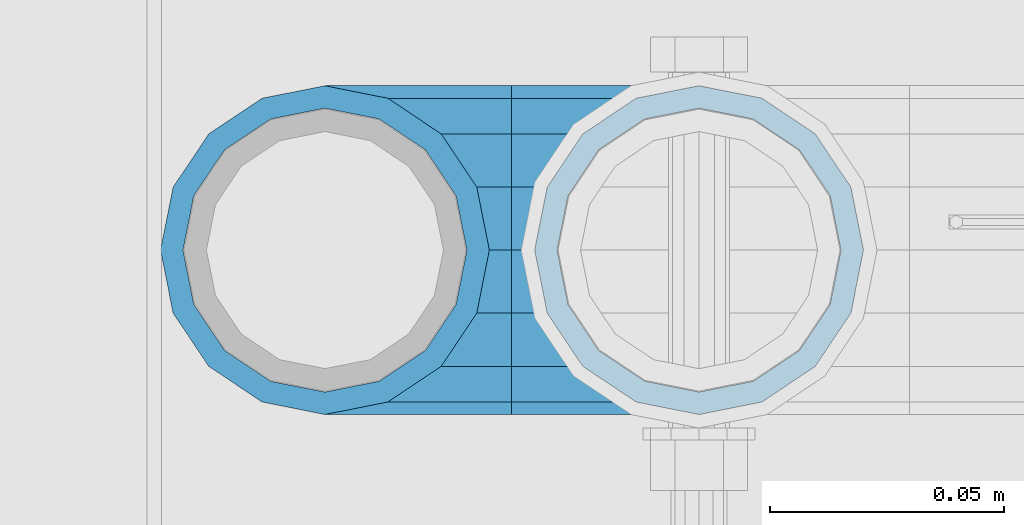
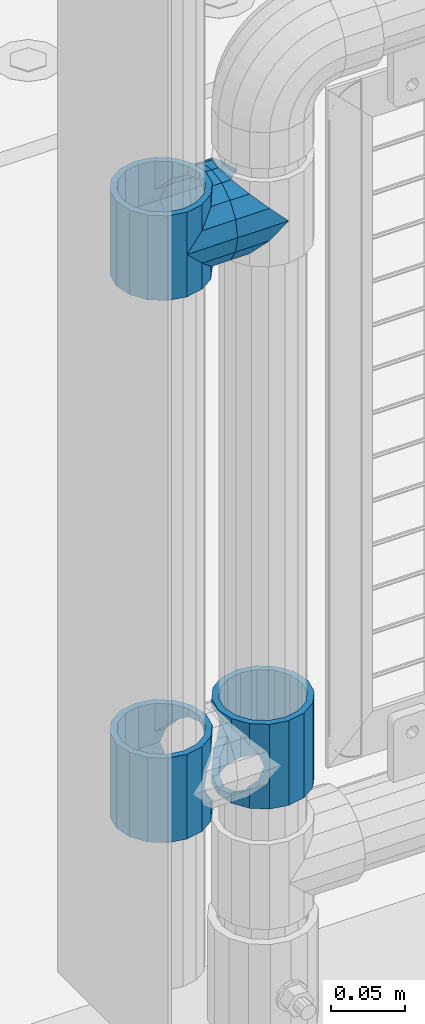
# One storey, part 145 of 240: 5 beams.
"""IFC2X3 building model written with IfcOpenShell, lengths in millimetres."""

from ifc_helpers import new_model, si_unit, frame, origin_with_axes, place, context, subcontext, project, spatial, faceted_brep, material, type_object, element, save


model = new_model("IFC2X3")

# Units and contexts
model_context = context("Model", 3, precision=1e-05, world=origin_with_axes())
body_context = subcontext(model_context, "Body", "Model", "MODEL_VIEW")
ifc_project = project(units=[si_unit("LENGTHUNIT", "METRE", prefix="MILLI"), si_unit("AREAUNIT", "SQUARE_METRE"), si_unit("VOLUMEUNIT", "CUBIC_METRE"), si_unit("MASSUNIT", "GRAM", prefix="KILO"), si_unit("TIMEUNIT", "SECOND"), si_unit("PLANEANGLEUNIT", "RADIAN"), si_unit("SOLIDANGLEUNIT", "STERADIAN"), si_unit("THERMODYNAMICTEMPERATUREUNIT", "DEGREE_CELSIUS"), si_unit("LUMINOUSINTENSITYUNIT", "LUMEN")], contexts=[model_context])

# Site, building, storey
site_placement = place(None, origin_with_axes())
site = spatial("IfcSite", under=ifc_project, at=site_placement, CompositionType="ELEMENT")
building_placement = place(site_placement, origin_with_axes())
building = spatial("IfcBuilding", under=site, at=building_placement, Name="Standard", CompositionType="ELEMENT")
storey_placement = place(building_placement, origin_with_axes())
storey = spatial("IfcBuildingStorey", under=building, at=storey_placement, Name="Undefined", CompositionType="ELEMENT", Elevation=0.0)

# Beams
ifc_material = material(Name="Misc_Undefined")
beam_type = type_object("IfcBeamType", PredefinedType="NOTDEFINED")
beam_1_placement = place(storey_placement, frame((42991.0, 34664.5, 433.820000000001), z_axis=(-1.0, 0.0, 0.0), x_axis=(0.0, 0.0, -1.0)))
element("IfcBeam", 1, at=beam_1_placement, inside=storey, type_object=beam_type, material=ifc_material, context=body_context, shape_type="Brep", body=[
    faceted_brep([(13.6893091909879, -21.4606908090136, -21.4606908090136), (13.6893091909879, -21.4606908090136, -27.1226768591223), (8.33762048232455, -13.4513226476338, -32.4743655677739), (7.11025618828211, -11.6144421722784, -32.8397438117245), (7.11025618828211, -11.6144421722784, -28.0397438117143), (23.5355578277191, -28.0397438117143, -11.6144421722784), (23.5355578277191, -28.0397438117143, -20.0882031229994), (18.7689575919987, -24.8548033587067, -24.8548033587067), (35.1500000000015, -30.35, 0.0), (35.1499999999996, -30.3499999999985, -16.6306603983758), (46.7644421722801, -28.0397438117143, -11.6144421722784), (46.7644421722801, -28.0397438117143, -20.0882031229994), (56.6106908090114, -21.4606908090136, -21.4606908090136), (56.6106908090114, -21.4606908090136, -27.1226768591223), (51.5310424080006, -24.8548033587067, -24.8548033587067), (63.1897438117172, -11.6144421722784, -28.0397438117143), (63.1897438117172, -11.6144421722784, -32.8397438117245), (61.9623795176703, -13.4513226476338, -32.4743655677739), (65.4999999999997, 0.0, -30.3499999999985), (65.4999999999997, 0.0, -35.1500000000015), (63.1897438117172, 11.6144421722784, -28.0397438117143), (63.1897438117172, 11.6144421722784, -32.8397438117172), (56.6106908090114, 21.4606908090136, -21.4606908090136), (56.6106908090114, 21.4606908090136, -27.1226768591077), (61.9623795176703, 13.4513226476338, -32.4743655677739), (46.7644421722801, 28.0397438117143, -11.6144421722784), (46.7644421722801, 28.0397438117143, -20.0882031229849), (51.5310424079941, 24.8548033587067, -24.8548033587067), (35.1500000000015, 30.35, 0.0), (35.1499999999996, 30.3499999999985, -16.6306603983685), (23.5355578277192, 28.0397438117143, -11.6144421722784), (23.5355578277192, 28.0397438117143, -20.0882031229849), (13.6893091909879, 21.4606908090136, -21.4606908090136), (13.6893091909879, 21.4606908090136, -27.1226768591077), (18.7689575919921, 24.8548033587067, -24.8548033587067), (7.11025618828211, 11.6144421722784, -28.0397438117143), (7.11025618828211, 11.6144421722784, -32.8397438117172), (8.33762048232893, 13.4513226476338, -32.4743655677739), (4.79999999999961, 0.0, -30.3499999999985), (4.79999999999961, 0.0, -35.1500000000015), (0.0, 21.4606908090136, 21.4606908090136), (0.0, 28.0397438117143, 11.6144421722784), (70.2999999999993, 28.0397438117143, 11.6144421722784), (70.2999999999993, 21.4606908090136, 21.4606908090136), (0.0, 11.6144421722784, 28.0397438117143), (70.2999999999993, 11.6144421722784, 28.0397438117143), (0.0, 0.0, 30.3499999999985), (70.2999999999993, 0.0, 30.3499999999985), (0.0, -11.6144421722784, 28.0397438117143), (70.2999999999993, -11.6144421722784, 28.0397438117143), (0.0, -21.4606908090136, 21.4606908090136), (70.2999999999993, -21.4606908090136, 21.4606908090136), (0.0, -28.0397438117143, 11.6144421722784), (70.2999999999993, -28.0397438117143, 11.6144421722784), (0.0, -24.8548033587067, -24.8548033587067), (0.0, -13.4513226476338, -32.4743655677739), (0.0, 0.0, -35.1500000000015), (0.0, -32.4743655677739, 13.4513226476338), (0.0, -35.1500000000015, 0.0), (70.2999999999993, -35.1500000000015, 0.0), (70.2999999999993, -32.4743655677739, 13.4513226476338), (0.0, -24.8548033587067, 24.8548033587067), (70.2999999999993, -24.8548033587067, 24.8548033587067), (0.0, -13.4513226476338, 32.4743655677739), (70.2999999999993, -13.4513226476338, 32.4743655677739), (0.0, 0.0, 35.1500000000015), (70.2999999999993, 0.0, 35.1500000000015), (0.0, 13.4513226476338, 32.4743655677739), (70.2999999999993, 13.4513226476338, 32.4743655677739), (0.0, 24.8548033587067, 24.8548033587067), (70.2999999999993, 24.8548033587067, 24.8548033587067), (0.0, 32.4743655677739, 13.4513226476338), (70.2999999999993, 32.4743655677739, 13.4513226476338), (0.0, 35.1500000000015, 0.0), (70.2999999999993, 35.1500000000015, 0.0), (0.0, 32.4743655677739, -13.4513226476338), (70.2999999999993, 32.4743655677739, -13.4513226476338), (70.2999999999993, -13.4513226476338, -32.4743655677739), (70.2999999999993, -24.8548033587067, -24.8548033587067), (70.2999999999993, 0.0, -35.1500000000015), (70.2999999999993, 13.4513226476338, -32.4743655677739), (70.2999999999993, 24.8548033587067, -24.8548033587067), (0.0, 24.8548033587067, -24.8548033587067), (0.0, 13.4513226476338, -32.4743655677739), (70.2999999999993, -32.4743655677739, -13.4513226476338), (0.0, -32.4743655677739, -13.4513226476338), (0.0, -28.0397438117143, -11.6144421722784), (0.0, -21.4606908090136, -21.4606908090136), (0.0, -11.6144421722784, -28.0397438117143), (0.0, 0.0, -30.3499999999985), (0.0, 11.6144421722784, -28.0397438117143), (0.0, 21.4606908090136, -21.4606908090136), (0.0, 28.0397438117143, -11.6144421722784), (0.0, 30.3499999999985, 0.0), (0.0, -30.3499999999985, 0.0), (70.2999999999993, 30.3499999999985, 0.0), (70.2999999999993, 28.0397438117143, -11.6144421722784), (70.2999999999993, 21.4606908090136, -21.4606908090136), (70.2999999999993, 11.6144421722784, -28.0397438117143), (70.2999999999993, 0.0, -30.3499999999985), (70.2999999999993, -11.6144421722784, -28.0397438117143), (70.2999999999993, -21.4606908090136, -21.4606908090136), (70.2999999999993, -28.0397438117143, -11.6144421722784), (70.2999999999993, -30.3499999999985, 0.0)], [[[0, 1, 2, 3, 4]], [[5, 6, 7, 1, 0]], [[8, 9, 6, 5]], [[10, 11, 9, 8]], [[12, 13, 14, 11, 10]], [[15, 16, 17, 13, 12]], [[18, 19, 16, 15]], [[20, 21, 19, 18]], [[22, 23, 24, 21, 20]], [[25, 26, 27, 23, 22]], [[28, 29, 26, 25]], [[30, 31, 29, 28]], [[32, 33, 34, 31, 30]], [[35, 36, 37, 33, 32]], [[38, 39, 36, 35]], [[4, 3, 39, 38]], [[40, 41, 42, 43]], [[44, 40, 43, 45]], [[46, 44, 45, 47]], [[48, 46, 47, 49]], [[50, 48, 49, 51]], [[52, 50, 51, 53]], [[54, 55, 2, 1, 7]], [[55, 56, 39, 3, 2]], [[57, 58, 59, 60]], [[61, 57, 60, 62]], [[63, 61, 62, 64]], [[65, 63, 64, 66]], [[67, 65, 66, 68]], [[69, 67, 68, 70]], [[71, 69, 70, 72]], [[73, 71, 72, 74]], [[75, 73, 74, 76]], [[17, 77, 78, 14, 13]], [[19, 79, 77, 17, 16]], [[80, 79, 19, 21, 24]], [[81, 80, 24, 23, 27]], [[34, 82, 75, 76, 81, 27, 26, 29, 31]], [[37, 83, 82, 34, 33]], [[39, 56, 83, 37, 36]], [[14, 78, 84, 85, 54, 7, 6, 9, 11]], [[58, 85, 84, 59]], [[57, 61, 63, 65, 67, 69, 71, 73, 75, 82, 83, 56, 55, 54, 85, 58], [86, 87, 88, 89, 90, 91, 92, 93, 41, 40, 44, 46, 48, 50, 52, 94]], [[90, 89, 38, 35]], [[91, 90, 35, 32]], [[92, 91, 32, 30]], [[93, 92, 30, 28]], [[41, 93, 28, 95, 42]], [[96, 95, 28, 25]], [[97, 96, 25, 22]], [[98, 97, 22, 20]], [[99, 98, 20, 18]], [[100, 99, 18, 15]], [[101, 100, 15, 12]], [[102, 101, 12, 10]], [[103, 102, 10, 8]], [[78, 77, 79, 80, 81, 76, 74, 72, 70, 68, 66, 64, 62, 60, 59, 84], [51, 49, 47, 45, 43, 42, 95, 96, 97, 98, 99, 100, 101, 102, 103, 53]], [[8, 94, 52, 53, 103]], [[86, 94, 8, 5]], [[87, 86, 5, 0]], [[88, 87, 0, 4]], [[89, 88, 4, 38]]]),
])
beam_2_placement = place(storey_placement, frame((43071.0, 34664.5, 433.820000000001), z_axis=(1.0, 0.0, 0.0), x_axis=(0.0, 0.0, -1.0)))
element("IfcBeam", 2, at=beam_2_placement, inside=storey, type_object=beam_type, material=ifc_material, context=body_context, shape_type="Brep", body=[
    faceted_brep([(46.7644421722801, 28.0397438117143, -11.6144421722784), (46.7644421722801, 28.0397438117143, -20.0882031229849), (51.5310424079941, 24.8548033587067, -24.8548033587067), (56.6106908090114, 21.4606908090136, -27.1226768591077), (56.6106908090114, 21.4606908090136, -21.4606908090136), (61.9623795176703, 13.4513226476338, -32.4743655677739), (63.1897438117172, 11.6144421722784, -32.8397438117172), (63.1897438117172, 11.6144421722784, -28.0397438117143), (65.4999999999997, 0.0, -35.1500000000015), (65.4999999999997, 0.0, -30.3499999999985), (63.1897438117172, -11.6144421722784, -32.8397438117245), (63.1897438117172, -11.6144421722784, -28.0397438117143), (61.9623795176703, -13.4513226476338, -32.4743655677739), (56.6106908090114, -21.4606908090136, -27.1226768591223), (56.6106908090114, -21.4606908090136, -21.4606908090136), (51.5310424080006, -24.8548033587067, -24.8548033587067), (46.7644421722801, -28.0397438117143, -20.0882031229994), (46.7644421722801, -28.0397438117143, -11.6144421722784), (35.1499999999996, -30.3499999999985, -16.6306603983758), (35.1500000000015, -30.35, 0.0), (23.5355578277191, -28.0397438117143, -20.0882031229994), (23.5355578277191, -28.0397438117143, -11.6144421722784), (18.7689575919987, -24.8548033587067, -24.8548033587067), (13.6893091909879, -21.4606908090136, -27.1226768591223), (13.6893091909879, -21.4606908090136, -21.4606908090136), (8.33762048232455, -13.4513226476338, -32.4743655677739), (7.11025618828211, -11.6144421722784, -32.8397438117245), (7.11025618828211, -11.6144421722784, -28.0397438117143), (4.79999999999961, 0.0, -35.1500000000015), (4.79999999999961, 0.0, -30.3499999999985), (7.11025618828211, 11.6144421722784, -32.8397438117172), (7.11025618828211, 11.6144421722784, -28.0397438117143), (8.33762048232893, 13.4513226476338, -32.4743655677739), (13.6893091909879, 21.4606908090136, -27.1226768591077), (13.6893091909879, 21.4606908090136, -21.4606908090136), (18.7689575919921, 24.8548033587067, -24.8548033587067), (23.5355578277192, 28.0397438117143, -20.0882031229849), (23.5355578277192, 28.0397438117143, -11.6144421722784), (35.1499999999996, 30.3499999999985, -16.6306603983685), (35.1500000000015, 30.35, 0.0), (0.0, 32.4743655677739, -13.4513226476338), (0.0, 35.1500000000015, 0.0), (70.2999999999993, 35.1500000000015, 0.0), (70.2999999999993, 32.4743655677739, -13.4513226476338), (0.0, 32.4743655677739, 13.4513226476338), (70.2999999999993, 32.4743655677739, 13.4513226476338), (0.0, 24.8548033587067, 24.8548033587067), (70.2999999999993, 24.8548033587067, 24.8548033587067), (0.0, 13.4513226476338, 32.4743655677739), (70.2999999999993, 13.4513226476338, 32.4743655677739), (0.0, 0.0, 35.1500000000015), (70.2999999999993, 0.0, 35.1500000000015), (0.0, -13.4513226476338, 32.4743655677739), (70.2999999999993, -13.4513226476338, 32.4743655677739), (0.0, -24.8548033587067, 24.8548033587067), (70.2999999999993, -24.8548033587067, 24.8548033587067), (0.0, -32.4743655677739, 13.4513226476338), (70.2999999999993, -32.4743655677739, 13.4513226476338), (0.0, -35.1500000000015, 0.0), (70.2999999999993, -35.1500000000015, 0.0), (70.2999999999993, -30.3499999999985, 0.0), (70.2999999999993, -28.0397438117143, -11.6144421722784), (70.2999999999993, -21.4606908090136, -21.4606908090136), (70.2999999999993, -11.6144421722784, -28.0397438117143), (70.2999999999993, 0.0, -30.3499999999985), (70.2999999999993, 11.6144421722784, -28.0397438117143), (70.2999999999993, 21.4606908090136, -21.4606908090136), (70.2999999999993, 28.0397438117143, -11.6144421722784), (0.0, -28.0397438117143, -11.6144421722784), (0.0, -30.3499999999985, 0.0), (0.0, -21.4606908090136, -21.4606908090136), (0.0, -11.6144421722784, -28.0397438117143), (0.0, 0.0, -30.3499999999985), (0.0, 11.6144421722784, -28.0397438117143), (0.0, 21.4606908090136, -21.4606908090136), (0.0, 28.0397438117143, -11.6144421722784), (0.0, 30.3499999999985, 0.0), (70.2999999999993, 30.3499999999985, 0.0), (0.0, 28.0397438117143, 11.6144421722784), (70.2999999999993, 28.0397438117143, 11.6144421722784), (0.0, 21.4606908090136, 21.4606908090136), (70.2999999999993, 21.4606908090136, 21.4606908090136), (0.0, 11.6144421722784, 28.0397438117143), (70.2999999999993, 11.6144421722784, 28.0397438117143), (0.0, 0.0, 30.3499999999985), (70.2999999999993, 0.0, 30.3499999999985), (0.0, -11.6144421722784, 28.0397438117143), (70.2999999999993, -11.6144421722784, 28.0397438117143), (0.0, -21.4606908090136, 21.4606908090136), (70.2999999999993, -21.4606908090136, 21.4606908090136), (0.0, -28.0397438117143, 11.6144421722784), (70.2999999999993, -28.0397438117143, 11.6144421722784), (70.2999999999993, -24.8548033587067, -24.8548033587067), (70.2999999999993, -13.4513226476338, -32.4743655677739), (70.2999999999993, 0.0, -35.1500000000015), (70.2999999999993, 13.4513226476338, -32.4743655677739), (70.2999999999993, 24.8548033587067, -24.8548033587067), (70.2999999999993, -32.4743655677739, -13.4513226476338), (0.0, -32.4743655677739, -13.4513226476338), (0.0, 24.8548033587067, -24.8548033587067), (0.0, 13.4513226476338, -32.4743655677739), (0.0, 0.0, -35.1500000000015), (0.0, -13.4513226476338, -32.4743655677739), (0.0, -24.8548033587067, -24.8548033587067)], [[[0, 1, 2, 3, 4]], [[4, 3, 5, 6, 7]], [[7, 6, 8, 9]], [[9, 8, 10, 11]], [[11, 10, 12, 13, 14]], [[14, 13, 15, 16, 17]], [[17, 16, 18, 19]], [[19, 18, 20, 21]], [[21, 20, 22, 23, 24]], [[24, 23, 25, 26, 27]], [[27, 26, 28, 29]], [[29, 28, 30, 31]], [[31, 30, 32, 33, 34]], [[34, 33, 35, 36, 37]], [[37, 36, 38, 39]], [[39, 38, 1, 0]], [[40, 41, 42, 43]], [[41, 44, 45, 42]], [[44, 46, 47, 45]], [[46, 48, 49, 47]], [[48, 50, 51, 49]], [[50, 52, 53, 51]], [[52, 54, 55, 53]], [[54, 56, 57, 55]], [[56, 58, 59, 57]], [[60, 61, 17, 19]], [[61, 62, 14, 17]], [[62, 63, 11, 14]], [[63, 64, 9, 11]], [[64, 65, 7, 9]], [[65, 66, 4, 7]], [[66, 67, 0, 4]], [[68, 69, 19, 21]], [[70, 68, 21, 24]], [[71, 70, 24, 27]], [[72, 71, 27, 29]], [[73, 72, 29, 31]], [[74, 73, 31, 34]], [[75, 74, 34, 37]], [[76, 75, 37, 39]], [[67, 77, 39, 0]], [[78, 76, 39, 77, 79]], [[80, 78, 79, 81]], [[82, 80, 81, 83]], [[84, 82, 83, 85]], [[86, 84, 85, 87]], [[88, 86, 87, 89]], [[90, 88, 89, 91]], [[19, 69, 90, 91, 60]], [[92, 93, 94, 95, 96, 43, 42, 45, 47, 49, 51, 53, 55, 57, 59, 97], [89, 87, 85, 83, 81, 79, 77, 67, 66, 65, 64, 63, 62, 61, 60, 91]], [[58, 98, 97, 59]], [[56, 54, 52, 50, 48, 46, 44, 41, 40, 99, 100, 101, 102, 103, 98, 58], [68, 70, 71, 72, 73, 74, 75, 76, 78, 80, 82, 84, 86, 88, 90, 69]], [[32, 100, 99, 35, 33]], [[28, 101, 100, 32, 30]], [[102, 101, 28, 26, 25]], [[103, 102, 25, 23, 22]], [[15, 92, 97, 98, 103, 22, 20, 18, 16]], [[12, 93, 92, 15, 13]], [[8, 94, 93, 12, 10]], [[95, 94, 8, 6, 5]], [[96, 95, 5, 3, 2]], [[35, 99, 40, 43, 96, 2, 1, 38, 36]]]),
])
beam_3_placement = place(storey_placement, frame((42991.0, 34664.5, 848.670000000001), z_axis=(0.0, -1.0, 0.0), x_axis=(1.0, 0.0, 0.0)))
element("IfcBeam", 3, at=beam_3_placement, inside=storey, type_object=beam_type, material=ifc_material, context=body_context, shape_type="Brep", body=[
    faceted_brep([(0.0, 0.0, -35.1500000000015), (13.4513226476338, -13.4513226476329, -32.4743655677739), (13.4513226476338, 13.4513226476329, -32.4743655677739), (32.4743655677739, 32.4743655677717, 13.4513226476338), (32.4743655677739, 26.8123795176755, 13.4513226476338), (27.1226768591005, 21.4606908090117, 21.4606908090136), (24.8548033587067, 16.3810424080013, 24.8548033587067), (24.8548033587067, 24.8548033587072, 24.8548033587067), (0.0, 0.0, 35.1500000000015), (13.4513226476338, 13.4513226476329, 32.4743655677739), (13.4513226476338, -13.4513226476329, 32.4743655677739), (20.0882031229849, 11.6144421722805, 28.0397438117143), (16.6306603983685, 0.0, 30.3499999999985), (20.0882031229849, -11.6144421722805, 28.0397438117143), (24.8548033587067, -16.3810424080078, 24.8548033587067), (24.8548033587067, -24.8548033587072, 24.8548033587067), (27.1226768591005, -21.4606908090117, 21.4606908090136), (32.4743655677739, -26.8123795176712, 13.4513226476338), (32.4743655677739, -32.4743655677717, 13.4513226476338), (32.8397438117099, -28.0397438117175, 11.6144421722784), (35.1500000000015, -30.35, 0.0), (35.1500000000015, -35.15, 0.0), (32.4743655677739, -26.8123795176712, -13.4513226476338), (32.4743655677739, -32.4743655677717, -13.4513226476338), (32.8397438117172, -28.0397438117175, -11.6144421722784), (24.8548033587067, -16.3810424079947, -24.8548033587067), (24.8548033587067, -24.8548033587072, -24.8548033587067), (27.1226768591223, -21.4606908090117, -21.4606908090136), (20.0882031229994, -11.6144421722805, -28.0397438117143), (16.6306603983758, 0.0, -30.3499999999985), (20.0882031229994, 11.6144421722805, -28.0397438117143), (24.8548033587067, 16.3810424080013, -24.8548033587067), (24.8548033587067, 24.8548033587072, -24.8548033587067), (27.1226768591223, 21.4606908090117, -21.4606908090136), (32.4743655677739, 26.8123795176712, -13.4513226476338), (32.4743655677739, 32.4743655677717, -13.4513226476338), (32.8397438117172, 28.0397438117175, -11.6144421722784), (35.1500000000015, 30.35, 0.0), (35.1500000000015, 35.15, 0.0), (32.8397438117099, 28.0397438117175, 11.6144421722784), (40.1500000000015, -35.15, 0.0), (40.1500000000015, -32.4743655677717, 13.4513226476338), (40.1500000000015, -24.8548033587072, 24.8548033587067), (40.1500000000015, -13.4513226476329, 32.4743655677739), (40.1500000000015, 0.0, 35.1500000000015), (40.1500000000015, 13.4513226476329, 32.4743655677739), (40.1500000000015, 24.8548033587072, 24.8548033587067), (40.1500000000015, 32.4743655677717, 13.4513226476338), (40.1500000000015, 35.15, 0.0), (40.1500000000015, -24.8548033587072, -24.8548033587067), (40.1500000000015, -32.4743655677717, -13.4513226476338), (40.1500000000015, -13.4513226476329, -32.4743655677739), (40.1500000000015, 0.0, -35.1500000000015), (40.1500000000015, 13.4513226476329, -32.4743655677739), (40.1500000000015, 24.8548033587072, -24.8548033587067), (40.1500000000015, 32.4743655677717, -13.4513226476338), (40.1500000000015, -21.4606908090117, 21.4606908090136), (40.1500000000015, -11.6144421722805, 28.0397438117143), (40.1500000000015, 0.0, 30.3499999999985), (40.1500000000015, 11.6144421722805, 28.0397438117143), (40.1500000000015, 21.4606908090117, 21.4606908090136), (40.1500000000015, 28.0397438117175, 11.6144421722784), (40.1500000000015, 30.35, 0.0), (40.1500000000015, 28.0397438117175, -11.6144421722784), (40.1500000000015, 21.4606908090117, -21.4606908090136), (40.1500000000015, 11.6144421722805, -28.0397438117143), (40.1500000000015, 0.0, -30.3499999999985), (40.1500000000015, -11.6144421722805, -28.0397438117143), (40.1500000000015, -21.4606908090117, -21.4606908090136), (40.1500000000015, -28.0397438117175, -11.6144421722784), (40.1500000000015, -30.35, 0.0), (40.1500000000015, -28.0397438117175, 11.6144421722784)], [[[0, 1, 2]], [[3, 4, 5, 6, 7]], [[8, 9, 10]], [[7, 6, 11, 12, 13, 14, 15, 10, 9]], [[16, 17, 18, 15, 14]], [[19, 20, 21, 18, 17]], [[22, 23, 21, 20, 24]], [[25, 26, 23, 22, 27]], [[2, 1, 26, 25, 28, 29, 30, 31, 32]], [[32, 31, 33, 34, 35]], [[35, 34, 36, 37, 38]], [[38, 37, 39, 4, 3]], [[40, 41, 18, 21]], [[41, 42, 15, 18]], [[42, 43, 10, 15]], [[43, 44, 8, 10]], [[44, 45, 9, 8]], [[45, 46, 7, 9]], [[46, 47, 3, 7]], [[47, 48, 38, 3]], [[49, 50, 23, 26]], [[51, 49, 26, 1]], [[52, 51, 1, 0]], [[53, 52, 0, 2]], [[54, 53, 2, 32]], [[55, 54, 32, 35]], [[48, 55, 35, 38]], [[50, 40, 21, 23]], [[49, 51, 52, 53, 54, 55, 48, 47, 46, 45, 44, 43, 42, 41, 40, 50], [56, 57, 58, 59, 60, 61, 62, 63, 64, 65, 66, 67, 68, 69, 70, 71]], [[63, 62, 37, 36]], [[33, 64, 63, 36, 34]], [[30, 65, 64, 33, 31]], [[66, 65, 30, 29]], [[67, 66, 29, 28]], [[68, 67, 28, 25, 27]], [[69, 68, 27, 22, 24]], [[70, 69, 24, 20]], [[71, 70, 20, 19]], [[16, 56, 71, 19, 17]], [[13, 57, 56, 16, 14]], [[58, 57, 13, 12]], [[59, 58, 12, 11]], [[60, 59, 11, 6, 5]], [[61, 60, 5, 4, 39]], [[62, 61, 39, 37]]]),
])
beam_4_placement = place(storey_placement, frame((43071.0, 34664.5, 848.670000000001), z_axis=(0.0, 1.0, 0.0), x_axis=(-1.0, 0.0, 0.0)))
element("IfcBeam", 4, at=beam_4_placement, inside=storey, type_object=beam_type, material=ifc_material, context=body_context, shape_type="Brep", body=[
    faceted_brep([(0.0, 0.0, -35.1500000000015), (13.4513226476338, -13.4513226476329, -32.4743655677739), (13.4513226476338, 13.4513226476329, -32.4743655677739), (27.1226768591005, -21.4606908090117, 21.4606908090136), (32.4743655677739, -26.8123795176712, 13.4513226476338), (32.4743655677739, -32.4743655677717, 13.4513226476338), (24.8548033587067, -24.8548033587072, 24.8548033587067), (24.8548033587067, -16.3810424080078, 24.8548033587067), (32.8397438117099, -28.0397438117175, 11.6144421722784), (35.1500000000015, -30.35, 0.0), (35.1500000000015, -35.15, 0.0), (32.4743655677739, -26.8123795176712, -13.4513226476338), (32.4743655677739, -32.4743655677717, -13.4513226476338), (32.8397438117172, -28.0397438117175, -11.6144421722784), (24.8548033587067, -16.3810424079947, -24.8548033587067), (24.8548033587067, -24.8548033587072, -24.8548033587067), (27.1226768591223, -21.4606908090117, -21.4606908090136), (20.0882031229994, -11.6144421722805, -28.0397438117143), (16.6306603983758, 0.0, -30.3499999999985), (20.0882031229994, 11.6144421722805, -28.0397438117143), (24.8548033587067, 16.3810424080013, -24.8548033587067), (24.8548033587067, 24.8548033587072, -24.8548033587067), (27.1226768591223, 21.4606908090117, -21.4606908090136), (32.4743655677739, 26.8123795176712, -13.4513226476338), (32.4743655677739, 32.4743655677717, -13.4513226476338), (32.8397438117172, 28.0397438117175, -11.6144421722784), (35.1500000000015, 30.35, 0.0), (35.1500000000015, 35.15, 0.0), (32.8397438117099, 28.0397438117175, 11.6144421722784), (32.4743655677739, 26.8123795176755, 13.4513226476338), (32.4743655677739, 32.4743655677717, 13.4513226476338), (27.1226768591005, 21.4606908090117, 21.4606908090136), (24.8548033587067, 16.3810424080013, 24.8548033587067), (24.8548033587067, 24.8548033587072, 24.8548033587067), (0.0, 0.0, 35.1500000000015), (13.4513226476338, 13.4513226476329, 32.4743655677739), (13.4513226476338, -13.4513226476329, 32.4743655677739), (20.0882031229849, 11.6144421722805, 28.0397438117143), (16.6306603983685, 0.0, 30.3499999999985), (20.0882031229849, -11.6144421722805, 28.0397438117143), (40.1500000000015, -35.15, 0.0), (40.1500000000015, -32.4743655677717, 13.4513226476338), (40.1500000000015, -24.8548033587072, 24.8548033587067), (40.1500000000015, -13.4513226476329, 32.4743655677739), (40.1500000000015, 0.0, 35.1500000000015), (40.1500000000015, -24.8548033587072, -24.8548033587067), (40.1500000000015, -32.4743655677717, -13.4513226476338), (40.1500000000015, -13.4513226476329, -32.4743655677739), (40.1500000000015, 0.0, -35.1500000000015), (40.1500000000015, 13.4513226476329, -32.4743655677739), (40.1500000000015, 24.8548033587072, -24.8548033587067), (40.1500000000015, 32.4743655677717, -13.4513226476338), (40.1500000000015, 35.15, 0.0), (40.1500000000015, 32.4743655677717, 13.4513226476338), (40.1500000000015, 24.8548033587072, 24.8548033587067), (40.1500000000015, 13.4513226476329, 32.4743655677739), (40.1500000000015, -21.4606908090117, 21.4606908090136), (40.1500000000015, -11.6144421722805, 28.0397438117143), (40.1500000000015, 0.0, 30.3499999999985), (40.1500000000015, 11.6144421722805, 28.0397438117143), (40.1500000000015, 21.4606908090117, 21.4606908090136), (40.1500000000015, 28.0397438117175, 11.6144421722784), (40.1500000000015, 30.35, 0.0), (40.1500000000015, 28.0397438117175, -11.6144421722784), (40.1500000000015, 21.4606908090117, -21.4606908090136), (40.1500000000015, 11.6144421722805, -28.0397438117143), (40.1500000000015, 0.0, -30.3499999999985), (40.1500000000015, -11.6144421722805, -28.0397438117143), (40.1500000000015, -21.4606908090117, -21.4606908090136), (40.1500000000015, -28.0397438117175, -11.6144421722784), (40.1500000000015, -30.35, 0.0), (40.1500000000015, -28.0397438117175, 11.6144421722784)], [[[0, 1, 2]], [[3, 4, 5, 6, 7]], [[8, 9, 10, 5, 4]], [[11, 12, 10, 9, 13]], [[14, 15, 12, 11, 16]], [[2, 1, 15, 14, 17, 18, 19, 20, 21]], [[21, 20, 22, 23, 24]], [[24, 23, 25, 26, 27]], [[27, 26, 28, 29, 30]], [[30, 29, 31, 32, 33]], [[34, 35, 36]], [[33, 32, 37, 38, 39, 7, 6, 36, 35]], [[40, 41, 5, 10]], [[41, 42, 6, 5]], [[42, 43, 36, 6]], [[43, 44, 34, 36]], [[45, 46, 12, 15]], [[47, 45, 15, 1]], [[48, 47, 1, 0]], [[49, 48, 0, 2]], [[50, 49, 2, 21]], [[51, 50, 21, 24]], [[52, 51, 24, 27]], [[53, 52, 27, 30]], [[54, 53, 30, 33]], [[55, 54, 33, 35]], [[44, 55, 35, 34]], [[46, 40, 10, 12]], [[45, 47, 48, 49, 50, 51, 52, 53, 54, 55, 44, 43, 42, 41, 40, 46], [56, 57, 58, 59, 60, 61, 62, 63, 64, 65, 66, 67, 68, 69, 70, 71]], [[59, 58, 38, 37]], [[60, 59, 37, 32, 31]], [[61, 60, 31, 29, 28]], [[62, 61, 28, 26]], [[63, 62, 26, 25]], [[22, 64, 63, 25, 23]], [[19, 65, 64, 22, 20]], [[66, 65, 19, 18]], [[67, 66, 18, 17]], [[68, 67, 17, 14, 16]], [[69, 68, 16, 11, 13]], [[70, 69, 13, 9]], [[71, 70, 9, 8]], [[3, 56, 71, 8, 4]], [[39, 57, 56, 3, 7]], [[58, 57, 39, 38]]]),
])
beam_5_placement = place(storey_placement, frame((42991.0, 34664.5, 883.820000000001), z_axis=(-1.0, 0.0, 0.0), x_axis=(0.0, 0.0, -1.0)))
element("IfcBeam", 5, at=beam_5_placement, inside=storey, type_object=beam_type, material=ifc_material, context=body_context, shape_type="Brep", body=[
    faceted_brep([(13.6893091909879, -21.4606908090136, -21.4606908090136), (13.6893091909879, -21.4606908090136, -27.1226768591223), (8.33762048232455, -13.4513226476338, -32.4743655677739), (7.11025618828211, -11.6144421722784, -32.8397438117245), (7.11025618828211, -11.6144421722784, -28.0397438117143), (23.5355578277191, -28.0397438117143, -11.6144421722784), (23.5355578277191, -28.0397438117143, -20.0882031229994), (18.7689575919987, -24.8548033587067, -24.8548033587067), (35.1500000000015, -30.35, 0.0), (35.1499999999996, -30.3499999999985, -16.6306603983758), (46.7644421722801, -28.0397438117143, -11.6144421722784), (46.7644421722801, -28.0397438117143, -20.0882031229994), (56.6106908090114, -21.4606908090136, -21.4606908090136), (56.6106908090114, -21.4606908090136, -27.1226768591223), (51.5310424080006, -24.8548033587067, -24.8548033587067), (63.1897438117172, -11.6144421722784, -28.0397438117143), (63.1897438117172, -11.6144421722784, -32.8397438117245), (61.9623795176703, -13.4513226476338, -32.4743655677739), (65.4999999999997, 0.0, -30.3499999999985), (65.4999999999997, 0.0, -35.1500000000015), (63.1897438117172, 11.6144421722784, -28.0397438117143), (63.1897438117172, 11.6144421722784, -32.8397438117172), (56.6106908090114, 21.4606908090136, -21.4606908090136), (56.6106908090114, 21.4606908090136, -27.1226768591077), (61.9623795176703, 13.4513226476338, -32.4743655677739), (46.7644421722801, 28.0397438117143, -11.6144421722784), (46.7644421722801, 28.0397438117143, -20.0882031229849), (51.5310424079941, 24.8548033587067, -24.8548033587067), (35.1500000000015, 30.35, 0.0), (35.1499999999996, 30.3499999999985, -16.6306603983685), (23.5355578277192, 28.0397438117143, -11.6144421722784), (23.5355578277192, 28.0397438117143, -20.0882031229849), (13.6893091909879, 21.4606908090136, -21.4606908090136), (13.6893091909879, 21.4606908090136, -27.1226768591077), (18.7689575919921, 24.8548033587067, -24.8548033587067), (7.11025618828211, 11.6144421722784, -28.0397438117143), (7.11025618828211, 11.6144421722784, -32.8397438117172), (8.33762048232893, 13.4513226476338, -32.4743655677739), (4.79999999999961, 0.0, -30.3499999999985), (4.79999999999961, 0.0, -35.1500000000015), (0.0, 21.4606908090136, 21.4606908090136), (0.0, 28.0397438117143, 11.6144421722784), (70.2999999999993, 28.0397438117143, 11.6144421722784), (70.2999999999993, 21.4606908090136, 21.4606908090136), (0.0, 11.6144421722784, 28.0397438117143), (70.2999999999993, 11.6144421722784, 28.0397438117143), (0.0, 0.0, 30.3499999999985), (70.2999999999993, 0.0, 30.3499999999985), (0.0, -11.6144421722784, 28.0397438117143), (70.2999999999993, -11.6144421722784, 28.0397438117143), (0.0, -21.4606908090136, 21.4606908090136), (70.2999999999993, -21.4606908090136, 21.4606908090136), (0.0, -28.0397438117143, 11.6144421722784), (70.2999999999993, -28.0397438117143, 11.6144421722784), (0.0, -24.8548033587067, -24.8548033587067), (0.0, -13.4513226476338, -32.4743655677739), (0.0, 0.0, -35.1500000000015), (0.0, -32.4743655677739, 13.4513226476338), (0.0, -35.1500000000015, 0.0), (70.2999999999993, -35.1500000000015, 0.0), (70.2999999999993, -32.4743655677739, 13.4513226476338), (0.0, -24.8548033587067, 24.8548033587067), (70.2999999999993, -24.8548033587067, 24.8548033587067), (0.0, -13.4513226476338, 32.4743655677739), (70.2999999999993, -13.4513226476338, 32.4743655677739), (0.0, 0.0, 35.1500000000015), (70.2999999999993, 0.0, 35.1500000000015), (0.0, 13.4513226476338, 32.4743655677739), (70.2999999999993, 13.4513226476338, 32.4743655677739), (0.0, 24.8548033587067, 24.8548033587067), (70.2999999999993, 24.8548033587067, 24.8548033587067), (0.0, 32.4743655677739, 13.4513226476338), (70.2999999999993, 32.4743655677739, 13.4513226476338), (0.0, 35.1500000000015, 0.0), (70.2999999999993, 35.1500000000015, 0.0), (0.0, 32.4743655677739, -13.4513226476338), (70.2999999999993, 32.4743655677739, -13.4513226476338), (70.2999999999993, -13.4513226476338, -32.4743655677739), (70.2999999999993, -24.8548033587067, -24.8548033587067), (70.2999999999993, 0.0, -35.1500000000015), (70.2999999999993, 13.4513226476338, -32.4743655677739), (70.2999999999993, 24.8548033587067, -24.8548033587067), (0.0, 24.8548033587067, -24.8548033587067), (0.0, 13.4513226476338, -32.4743655677739), (70.2999999999993, -32.4743655677739, -13.4513226476338), (0.0, -32.4743655677739, -13.4513226476338), (0.0, -28.0397438117143, -11.6144421722784), (0.0, -21.4606908090136, -21.4606908090136), (0.0, -11.6144421722784, -28.0397438117143), (0.0, 0.0, -30.3499999999985), (0.0, 11.6144421722784, -28.0397438117143), (0.0, 21.4606908090136, -21.4606908090136), (0.0, 28.0397438117143, -11.6144421722784), (0.0, 30.3499999999985, 0.0), (0.0, -30.3499999999985, 0.0), (70.2999999999993, 30.3499999999985, 0.0), (70.2999999999993, 28.0397438117143, -11.6144421722784), (70.2999999999993, 21.4606908090136, -21.4606908090136), (70.2999999999993, 11.6144421722784, -28.0397438117143), (70.2999999999993, 0.0, -30.3499999999985), (70.2999999999993, -11.6144421722784, -28.0397438117143), (70.2999999999993, -21.4606908090136, -21.4606908090136), (70.2999999999993, -28.0397438117143, -11.6144421722784), (70.2999999999993, -30.3499999999985, 0.0)], [[[0, 1, 2, 3, 4]], [[5, 6, 7, 1, 0]], [[8, 9, 6, 5]], [[10, 11, 9, 8]], [[12, 13, 14, 11, 10]], [[15, 16, 17, 13, 12]], [[18, 19, 16, 15]], [[20, 21, 19, 18]], [[22, 23, 24, 21, 20]], [[25, 26, 27, 23, 22]], [[28, 29, 26, 25]], [[30, 31, 29, 28]], [[32, 33, 34, 31, 30]], [[35, 36, 37, 33, 32]], [[38, 39, 36, 35]], [[4, 3, 39, 38]], [[40, 41, 42, 43]], [[44, 40, 43, 45]], [[46, 44, 45, 47]], [[48, 46, 47, 49]], [[50, 48, 49, 51]], [[52, 50, 51, 53]], [[54, 55, 2, 1, 7]], [[55, 56, 39, 3, 2]], [[57, 58, 59, 60]], [[61, 57, 60, 62]], [[63, 61, 62, 64]], [[65, 63, 64, 66]], [[67, 65, 66, 68]], [[69, 67, 68, 70]], [[71, 69, 70, 72]], [[73, 71, 72, 74]], [[75, 73, 74, 76]], [[17, 77, 78, 14, 13]], [[19, 79, 77, 17, 16]], [[80, 79, 19, 21, 24]], [[81, 80, 24, 23, 27]], [[34, 82, 75, 76, 81, 27, 26, 29, 31]], [[37, 83, 82, 34, 33]], [[39, 56, 83, 37, 36]], [[14, 78, 84, 85, 54, 7, 6, 9, 11]], [[58, 85, 84, 59]], [[57, 61, 63, 65, 67, 69, 71, 73, 75, 82, 83, 56, 55, 54, 85, 58], [86, 87, 88, 89, 90, 91, 92, 93, 41, 40, 44, 46, 48, 50, 52, 94]], [[90, 89, 38, 35]], [[91, 90, 35, 32]], [[92, 91, 32, 30]], [[93, 92, 30, 28]], [[41, 93, 28, 95, 42]], [[96, 95, 28, 25]], [[97, 96, 25, 22]], [[98, 97, 22, 20]], [[99, 98, 20, 18]], [[100, 99, 18, 15]], [[101, 100, 15, 12]], [[102, 101, 12, 10]], [[103, 102, 10, 8]], [[78, 77, 79, 80, 81, 76, 74, 72, 70, 68, 66, 64, 62, 60, 59, 84], [51, 49, 47, 45, 43, 42, 95, 96, 97, 98, 99, 100, 101, 102, 103, 53]], [[8, 94, 52, 53, 103]], [[86, 94, 8, 5]], [[87, 86, 5, 0]], [[88, 87, 0, 4]], [[89, 88, 4, 38]]]),
])

save(model, "model.ifc")
